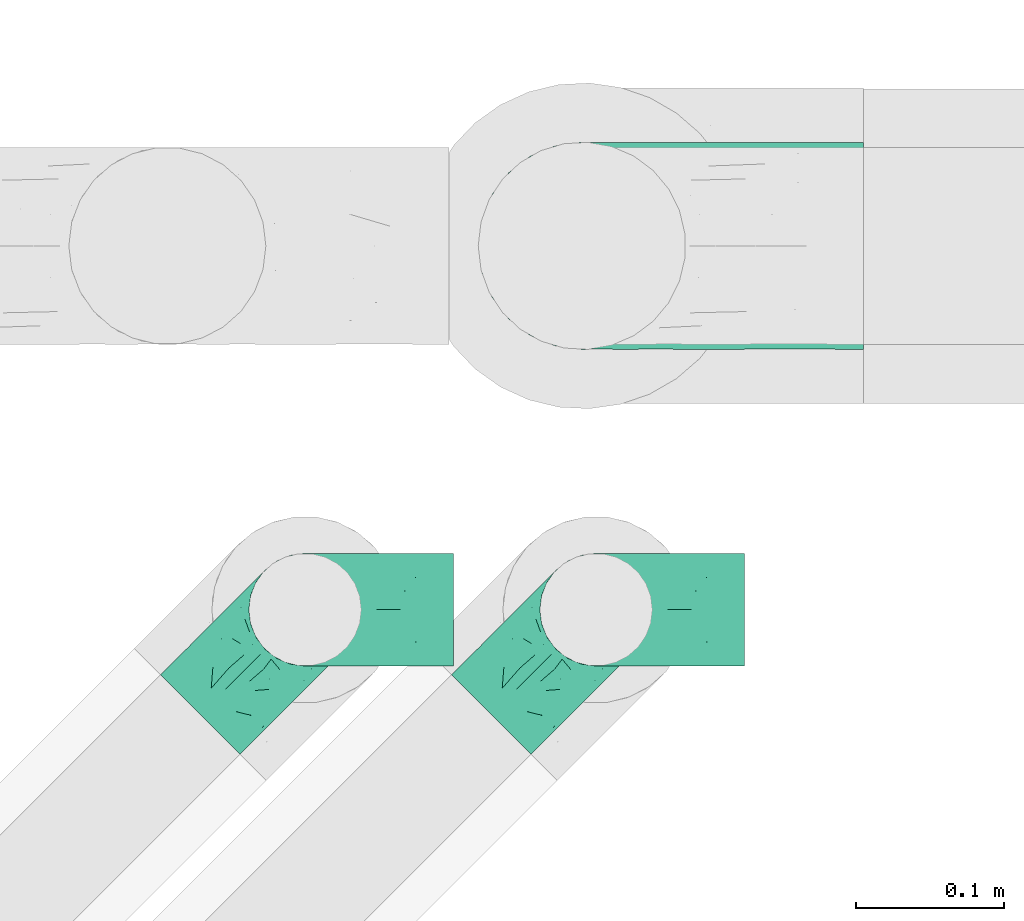
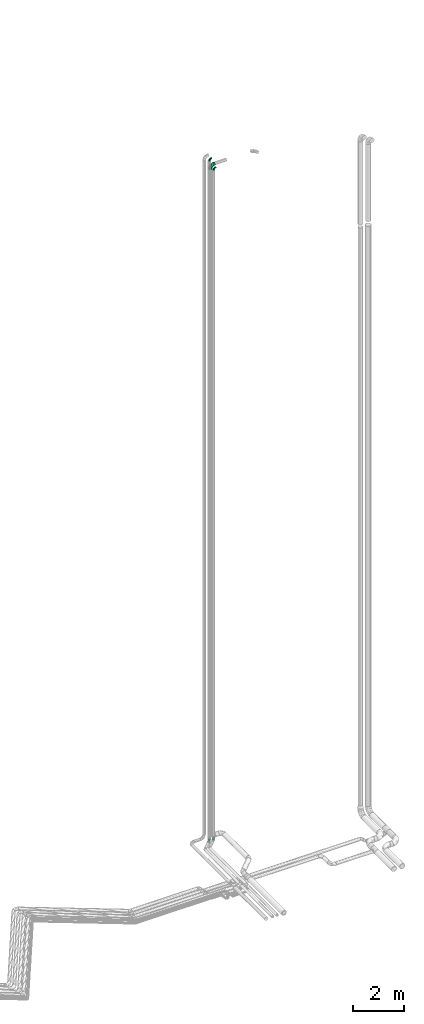
# One storey, part 71 of 93: 5 flow fittings.
"""IFC2X3 building model written with IfcOpenShell, lengths in millimetres."""

from ifc_helpers import new_model, entity, si_unit, converted_unit, derived_unit, direction, frame, origin, place, context, subcontext, project, spatial, faceted_brep, source, transform, mapped, material, type_object, type_shapes, element, save


model = new_model("IFC2X3")

# Units and contexts
model_context = context("Model", 3, precision=0.01, world=origin(), true_north=direction((6.12303176911189e-17, 1.0)))
body_context = subcontext(model_context, "Body", "Model", "MODEL_VIEW")
ifc_project = project(units=[si_unit("LENGTHUNIT", "METRE", prefix="MILLI"), si_unit("AREAUNIT", "SQUARE_METRE"), si_unit("VOLUMEUNIT", "CUBIC_METRE"), converted_unit("PLANEANGLEUNIT", "DEGREE", entity("IfcRatioMeasure", 0.0174532925199433), si_unit("PLANEANGLEUNIT", "RADIAN"), dimensions=[0, 0, 0, 0, 0, 0, 0]), si_unit("MASSUNIT", "GRAM", prefix="KILO"), derived_unit("MASSDENSITYUNIT", [(si_unit("MASSUNIT", "GRAM", prefix="KILO"), 1), (si_unit("LENGTHUNIT", "METRE"), -3)]), derived_unit("MOMENTOFINERTIAUNIT", [(si_unit("LENGTHUNIT", "METRE"), 4)]), si_unit("TIMEUNIT", "SECOND"), si_unit("FREQUENCYUNIT", "HERTZ"), si_unit("THERMODYNAMICTEMPERATUREUNIT", "DEGREE_CELSIUS"), derived_unit("THERMALTRANSMITTANCEUNIT", [(si_unit("MASSUNIT", "GRAM", prefix="KILO"), 1), (si_unit("THERMODYNAMICTEMPERATUREUNIT", "KELVIN"), -1), (si_unit("TIMEUNIT", "SECOND"), -3)]), derived_unit("VOLUMETRICFLOWRATEUNIT", [(si_unit("LENGTHUNIT", "METRE"), 3), (si_unit("TIMEUNIT", "SECOND"), -1)]), derived_unit("MASSFLOWRATEUNIT", [(si_unit("MASSUNIT", "GRAM", prefix="KILO"), 1), (si_unit("TIMEUNIT", "SECOND"), -1)]), derived_unit("ROTATIONALFREQUENCYUNIT", [(si_unit("TIMEUNIT", "SECOND"), -1)]), si_unit("ELECTRICCURRENTUNIT", "AMPERE"), si_unit("ELECTRICVOLTAGEUNIT", "VOLT"), si_unit("POWERUNIT", "WATT"), si_unit("FORCEUNIT", "NEWTON", prefix="KILO"), si_unit("ILLUMINANCEUNIT", "LUX"), si_unit("LUMINOUSFLUXUNIT", "LUMEN"), si_unit("LUMINOUSINTENSITYUNIT", "CANDELA"), derived_unit("USERDEFINED", [(si_unit("MASSUNIT", "GRAM", prefix="KILO"), -1), (si_unit("LENGTHUNIT", "METRE"), -2), (si_unit("TIMEUNIT", "SECOND"), 3), (si_unit("LUMINOUSFLUXUNIT", "LUMEN"), 1)]), derived_unit("LINEARVELOCITYUNIT", [(si_unit("LENGTHUNIT", "METRE"), 1), (si_unit("TIMEUNIT", "SECOND"), -1)]), si_unit("PRESSUREUNIT", "PASCAL"), derived_unit("USERDEFINED", [(si_unit("LENGTHUNIT", "METRE"), -2), (si_unit("MASSUNIT", "GRAM", prefix="KILO"), 1), (si_unit("TIMEUNIT", "SECOND"), -2)]), derived_unit("LINEARFORCEUNIT", [(si_unit("MASSUNIT", "GRAM", prefix="KILO"), 1), (si_unit("LENGTHUNIT", "METRE"), 1), (si_unit("TIMEUNIT", "SECOND"), -2), (si_unit("LENGTHUNIT", "METRE"), -1)]), derived_unit("PLANARFORCEUNIT", [(si_unit("MASSUNIT", "GRAM", prefix="KILO"), 1), (si_unit("LENGTHUNIT", "METRE"), 1), (si_unit("TIMEUNIT", "SECOND"), -2), (si_unit("LENGTHUNIT", "METRE"), -2)])], contexts=[model_context])

# Site, building, storey
site_placement = place(None, origin())
site = spatial("IfcSite", under=ifc_project, at=site_placement, CompositionType="ELEMENT")
building_placement = place(site_placement, origin())
building = spatial("IfcBuilding", under=site, at=building_placement, CompositionType="ELEMENT")
storey_placement = place(building_placement, frame((0.0, 0.0, -4200.0)))
storey = spatial("IfcBuildingStorey", under=building, at=storey_placement, CompositionType="ELEMENT", Elevation=-4200.0)

# Flow fittings
ifc_material = material()
pipe_fitting_type_1 = type_object("IfcPipeFittingType", Name="ADSK_2", PredefinedType="NOTDEFINED", material=ifc_material)
shared_shape_1 = source(origin(), body_context, "Body", "Brep", [
    faceted_brep([(-100.0, 19.0, -32.91), (-100.0, 9.84, -36.71), (-100.0, 0.0, -38.0), (-100.0, -9.84, -36.71), (-100.0, -19.0, -32.91), (-100.0, -26.87, -26.87), (-100.0, -32.91, -19.0), (-100.0, -36.71, -9.84), (-100.0, -38.0, 0.0), (-100.0, -36.71, 9.84), (-100.0, -32.91, 19.0), (-100.0, -26.87, 26.87), (-100.0, -19.0, 32.91), (-100.0, -9.84, 36.71), (-100.0, 0.0, 38.0), (-100.0, 9.84, 36.71), (-100.0, 19.0, 32.91), (-100.0, 26.87, 26.87), (-100.0, 32.91, 19.0), (-100.0, 36.71, 9.84), (-100.0, 38.0, 0.0), (-100.0, 36.71, -9.84), (-100.0, 32.91, -19.0), (-100.0, 26.87, -26.87), (0.0, 100.0, -38.0), (-9.84, 100.0, -36.71), (-19.0, 100.0, -32.91), (-26.87, 100.0, -26.87), (-32.91, 100.0, -19.0), (-36.71, 100.0, -9.84), (-38.0, 100.0, 0.0), (-36.71, 100.0, 9.84), (-32.91, 100.0, 19.0), (-26.87, 100.0, 26.87), (-19.0, 100.0, 32.91), (-9.84, 100.0, 36.71), (0.0, 100.0, 38.0), (9.84, 100.0, 36.71), (19.0, 100.0, 32.91), (26.87, 100.0, 26.87), (32.91, 100.0, 19.0), (36.71, 100.0, 9.84), (38.0, 100.0, 0.0), (36.71, 100.0, -9.84), (32.91, 100.0, -19.0), (26.87, 100.0, -26.87), (19.0, 100.0, -32.91), (9.84, 100.0, -36.71), (-40.69, 71.44, 16.62), (-81.22, -35.53, 0.0), (-67.52, -31.95, 12.5), (-8.97, -2.95, 6.59), (-11.71, -2.76, 13.62), (-24.68, -14.61, 8.04), (-64.28, -33.3, 0.0), (-83.72, 23.85, 30.89), (-76.19, 33.07, 24.6), (-74.13, -28.58, 21.76), (13.92, 43.47, 26.56), (5.03, 42.28, 32.41), (2.17, 22.78, 25.61), (20.11, 65.77, 28.71), (-65.77, -20.11, 28.71), (-74.23, -13.22, 34.41), (-44.44, -24.14, 12.16), (-47.64, -26.4, 0.0), (-31.0, -19.51, 0.0), (-54.86, 48.59, 21.12), (-81.56, 37.18, 15.86), (-42.28, -5.03, 32.41), (-52.67, 2.67, 37.1), (-14.76, 85.65, 35.5), (-6.46, 75.04, 37.87), (-58.38, 40.19, 26.6), (-15.88, 37.27, 37.68), (-29.21, 13.39, 36.1), (-10.53, 30.95, 35.7), (-77.78, -4.12, 37.45), (-2.67, 52.67, 37.1), (-76.41, 41.64, 8.45), (-71.15, 7.29, 37.89), (-32.26, 79.13, 24.41), (-44.28, 53.84, 26.08), (-25.18, 76.9, 31.2), (19.6, 43.38, 19.97), (6.25, 18.29, 16.9), (19.92, 34.73, 10.46), (-60.8, 50.97, 7.63), (-76.27, 42.72, 0.0), (-77.34, 15.98, 35.72), (-15.11, 15.11, 32.27), (-22.78, -2.17, 25.61), (28.58, 74.13, 21.76), (31.95, 67.52, 12.5), (-51.02, 30.39, 34.96), (-54.69, 20.06, 37.12), (26.4, 47.64, 0.0), (-51.15, 12.85, 38.0), (-32.84, 22.95, 37.94), (4.12, 77.78, 37.45), (-43.38, -19.6, 19.97), (35.53, 81.22, 0.0), (13.22, 74.23, 34.41), (-39.82, 82.33, 7.34), (-42.72, 76.27, 0.0), (-33.83, 52.47, 33.18), (-48.09, 40.81, 31.48), (-56.16, 56.16, 0.0), (-48.2, 64.18, 8.55), (-18.69, 66.93, 35.98), (-49.98, 57.58, 16.12), (-62.54, 46.99, 14.59), (-43.26, -12.84, 27.42), (-17.52, 48.72, 37.89), (-64.19, 29.4, 31.78), (-27.05, 50.9, 36.03), (-36.14, 36.14, 36.75), (-23.99, -8.71, 19.44), (6.3, 13.34, 7.98), (19.51, 31.0, 0.0), (-7.64, 6.3, 21.15), (-16.71, -8.55, 0.0), (33.3, 64.28, 0.0), (-2.42, 2.42, 0.0), (8.55, 16.71, 0.0), (-85.65, 14.76, -35.5), (-23.85, 83.72, -30.89), (-33.07, 76.19, -24.6), (-75.04, 6.46, -37.87), (-37.27, 15.88, -37.68), (-13.39, 29.21, -36.1), (-30.95, 10.53, -35.7), (-79.13, 32.26, -24.41), (-76.9, 25.18, -31.2), (6.3, 13.34, -7.98), (-11.71, -2.76, -13.62), (6.25, 18.29, -16.9), (-82.33, 39.82, -7.34), (-66.93, 18.69, -35.98), (-48.72, 17.52, -37.89), (-64.18, 48.2, -8.55), (31.95, 67.52, -12.5), (28.58, 74.13, -21.76), (-52.47, 33.83, -33.18), (4.12, 77.78, -37.45), (-7.29, 71.15, -37.89), (-15.98, 77.34, -35.72), (-67.52, -31.95, -12.5), (-30.39, 51.02, -34.96), (-20.06, 54.69, -37.12), (-48.59, 54.86, -21.12), (-37.18, 81.56, -15.86), (-74.13, -28.58, -21.76), (-29.4, 64.19, -31.78), (-40.81, 48.09, -31.48), (-40.19, 58.38, -26.6), (-65.77, -20.11, -28.71), (-74.23, -13.22, -34.41), (-39.81, -22.62, -10.22), (-77.78, -4.12, -37.45), (-43.38, -19.6, -19.97), (-12.85, 51.15, -38.0), (-22.95, 32.84, -37.94), (-71.44, 40.69, -16.62), (19.6, 43.38, -19.97), (20.11, 65.77, -28.71), (-52.67, 2.67, -37.1), (-53.84, 44.28, -26.08), (-41.64, 76.41, -8.45), (-23.99, -8.71, -19.44), (-43.47, -13.92, -26.56), (-22.78, -2.17, -25.61), (-20.59, -12.11, -6.83), (13.22, 74.23, -34.41), (5.03, 42.28, -32.41), (-2.67, 52.67, -37.1), (19.92, 34.73, -10.46), (-42.28, -5.03, -32.41), (12.84, 43.26, -27.42), (-50.97, 60.8, -7.63), (-57.58, 49.98, -16.12), (-46.99, 62.54, -14.59), (-50.9, 27.05, -36.03), (-36.14, 36.14, -36.75), (-15.11, 15.11, -32.27), (2.17, 22.78, -25.61), (-7.64, 6.3, -21.15), (-6.28, -0.33, -7.3)], [[[0, 1, 2, 3, 4, 5, 6, 7, 8, 9, 10, 11, 12, 13, 14, 15, 16, 17, 18, 19, 20, 21, 22, 23]], [[24, 25, 26, 27, 28, 29, 30, 31, 32, 33, 34, 35, 36, 37, 38, 39, 40, 41, 42, 43, 44, 45, 46, 47]], [[32, 31, 48]], [[49, 50, 9]], [[51, 52, 53]], [[9, 50, 10]], [[54, 50, 49]], [[17, 55, 56]], [[11, 10, 57]], [[58, 59, 60]], [[61, 39, 38]], [[62, 12, 11]], [[62, 63, 12]], [[64, 65, 66]], [[56, 67, 68]], [[63, 69, 70]], [[35, 71, 72]], [[67, 56, 73]], [[74, 75, 76]], [[16, 55, 17]], [[13, 77, 14]], [[76, 78, 74]], [[68, 79, 19]], [[18, 17, 56]], [[14, 77, 80]], [[20, 19, 79]], [[81, 82, 83]], [[84, 85, 86]], [[87, 88, 79]], [[18, 68, 19]], [[15, 89, 16]], [[14, 80, 15]], [[85, 84, 60]], [[90, 69, 91]], [[92, 84, 93]], [[94, 89, 95]], [[86, 96, 93]], [[83, 71, 34]], [[95, 97, 98]], [[37, 36, 99]], [[40, 39, 92]], [[40, 93, 41]], [[66, 53, 64]], [[92, 93, 40]], [[57, 100, 62]], [[93, 101, 41]], [[93, 84, 86]], [[61, 102, 59]], [[34, 33, 83]], [[103, 48, 31]], [[50, 57, 10]], [[104, 103, 30]], [[94, 105, 106]], [[104, 107, 108]], [[12, 63, 13]], [[83, 109, 71]], [[83, 105, 109]], [[33, 81, 83]], [[67, 110, 111]], [[108, 103, 104]], [[112, 69, 62]], [[34, 71, 35]], [[36, 35, 72]], [[109, 113, 72]], [[102, 38, 37]], [[102, 61, 38]], [[114, 106, 73]], [[89, 15, 80]], [[33, 32, 81]], [[115, 105, 116]], [[109, 115, 113]], [[99, 72, 78]], [[111, 87, 79]], [[108, 87, 110]], [[69, 63, 62]], [[77, 63, 70]], [[100, 117, 112]], [[69, 90, 75]], [[99, 102, 37]], [[78, 76, 59]], [[78, 59, 102]], [[59, 90, 60]], [[100, 57, 50]], [[62, 11, 57]], [[39, 61, 92]], [[84, 92, 61]], [[95, 89, 80]], [[55, 89, 114]], [[83, 82, 105]], [[94, 106, 114]], [[98, 113, 116]], [[78, 72, 113]], [[98, 116, 95]], [[98, 70, 75]], [[32, 48, 81]], [[82, 81, 48]], [[91, 112, 117]], [[60, 84, 58]], [[113, 115, 116]], [[118, 119, 86]], [[90, 91, 60]], [[91, 117, 120]], [[72, 99, 36]], [[102, 99, 78]], [[63, 77, 13]], [[80, 77, 70]], [[95, 80, 97]], [[94, 95, 116]], [[56, 68, 18]], [[79, 68, 111]], [[110, 87, 111]], [[79, 88, 20]], [[108, 107, 87]], [[88, 87, 107]], [[120, 60, 91]], [[66, 121, 53]], [[118, 86, 85]], [[122, 93, 96]], [[52, 118, 85]], [[118, 123, 124, 119]], [[48, 103, 108]], [[30, 103, 31]], [[89, 55, 16]], [[56, 55, 114]], [[80, 70, 97]], [[70, 98, 97]], [[105, 94, 116]], [[89, 94, 114]], [[105, 82, 106]], [[73, 106, 82]], [[67, 73, 82]], [[114, 73, 56]], [[110, 82, 48]], [[67, 111, 68]], [[82, 110, 67]], [[108, 110, 48]], [[69, 75, 70]], [[76, 75, 90]], [[59, 76, 90]], [[78, 113, 74]], [[113, 98, 74]], [[75, 74, 98]], [[9, 8, 49]], [[101, 93, 122]], [[101, 42, 41]], [[72, 71, 109]], [[50, 54, 65]], [[117, 53, 52]], [[109, 105, 115]], [[100, 112, 62]], [[91, 69, 112]], [[123, 51, 121]], [[120, 52, 85]], [[52, 120, 117]], [[60, 120, 85]], [[51, 118, 52]], [[100, 64, 117]], [[50, 64, 100]], [[121, 51, 53]], [[118, 51, 123]], [[84, 61, 58]], [[59, 58, 61]], [[86, 119, 96]], [[65, 64, 50]], [[117, 64, 53]], [[125, 1, 0]], [[27, 126, 127]], [[2, 1, 128]], [[129, 130, 131]], [[132, 133, 23]], [[134, 135, 136]], [[88, 137, 20]], [[138, 139, 128]], [[88, 107, 140]], [[141, 142, 44]], [[138, 133, 143]], [[24, 144, 145]], [[146, 25, 145]], [[125, 133, 138]], [[6, 147, 7]], [[148, 146, 149]], [[147, 49, 7]], [[127, 150, 151]], [[147, 6, 152]], [[153, 154, 155]], [[156, 4, 157]], [[140, 137, 88]], [[24, 145, 25]], [[43, 42, 101]], [[65, 147, 158]], [[148, 143, 154]], [[159, 3, 2]], [[147, 152, 160]], [[149, 161, 162]], [[156, 5, 4]], [[137, 163, 21]], [[142, 164, 165]], [[131, 166, 129]], [[28, 151, 29]], [[167, 133, 132]], [[168, 30, 29]], [[169, 170, 171]], [[127, 28, 27]], [[150, 127, 155]], [[135, 172, 158]], [[26, 25, 146]], [[1, 125, 128]], [[22, 21, 163]], [[126, 27, 26]], [[151, 168, 29]], [[24, 47, 144]], [[45, 165, 46]], [[0, 23, 133]], [[173, 174, 175]], [[119, 134, 176]], [[142, 45, 44]], [[173, 46, 165]], [[141, 44, 43]], [[46, 173, 47]], [[141, 101, 122]], [[156, 157, 177]], [[157, 4, 3]], [[101, 141, 43]], [[178, 174, 165]], [[169, 160, 170]], [[6, 5, 152]], [[170, 177, 171]], [[158, 147, 160]], [[104, 168, 179]], [[141, 96, 176]], [[150, 180, 181]], [[23, 22, 132]], [[182, 143, 183]], [[138, 182, 139]], [[159, 128, 166]], [[181, 179, 168]], [[140, 179, 180]], [[159, 157, 3]], [[166, 131, 177]], [[166, 177, 157]], [[177, 184, 171]], [[174, 173, 165]], [[144, 173, 175]], [[178, 164, 185]], [[174, 184, 130]], [[5, 156, 152]], [[160, 152, 156]], [[164, 142, 141]], [[165, 45, 142]], [[149, 146, 145]], [[126, 146, 153]], [[133, 167, 143]], [[148, 154, 153]], [[162, 139, 183]], [[166, 128, 139]], [[162, 183, 149]], [[162, 175, 130]], [[22, 163, 132]], [[167, 132, 163]], [[174, 185, 184]], [[136, 176, 134]], [[185, 136, 186]], [[158, 172, 66]], [[136, 185, 164]], [[171, 184, 185]], [[128, 159, 2]], [[157, 159, 166]], [[173, 144, 47]], [[145, 144, 175]], [[149, 145, 161]], [[148, 149, 183]], [[127, 151, 28]], [[168, 151, 181]], [[180, 179, 181]], [[168, 104, 30]], [[140, 107, 179]], [[104, 179, 107]], [[176, 136, 164]], [[135, 169, 186]], [[141, 176, 164]], [[134, 119, 124, 123]], [[158, 66, 65]], [[187, 172, 135]], [[163, 137, 140]], [[20, 137, 21]], [[146, 126, 26]], [[127, 126, 153]], [[145, 175, 161]], [[175, 162, 161]], [[143, 148, 183]], [[146, 148, 153]], [[143, 167, 154]], [[155, 154, 167]], [[150, 155, 167]], [[153, 155, 127]], [[180, 167, 163]], [[150, 181, 151]], [[167, 180, 150]], [[140, 180, 163]], [[174, 130, 175]], [[131, 130, 184]], [[177, 131, 184]], [[166, 139, 129]], [[139, 162, 129]], [[130, 129, 162]], [[49, 147, 54]], [[49, 8, 7]], [[133, 125, 0]], [[128, 125, 138]], [[158, 160, 169]], [[65, 54, 147]], [[187, 135, 134]], [[187, 121, 172]], [[134, 123, 187]], [[139, 182, 183]], [[121, 187, 123]], [[121, 66, 172]], [[138, 143, 182]], [[160, 156, 170]], [[177, 170, 156]], [[186, 169, 171]], [[158, 169, 135]], [[185, 186, 171]], [[135, 186, 136]], [[164, 178, 165]], [[185, 174, 178]], [[96, 141, 122]], [[96, 119, 176]]]),
])
type_shapes(pipe_fitting_type_1, [shared_shape_1])
for number, where, z_axis, x_axis, name in (
    (1, (25108.72, 12070.0, 3000.0), (0.707106781186543, -0.707106781186552, 0.0), (0.707106781186552, 0.707106781186543, 0.0), "ADSK_2"),
    (2, (24912.31, 12070.0, 3000.0), (0.707106781186536, -0.707106781186559, 0.0), (0.707106781186559, 0.707106781186536, 0.0), "ADSK_2"),
    (3, (25108.72, 12070.0, 35000.0), (0.0, 1.0, 0.0), (0.0, 0.0, 1.0), "ADSK_2"),
    (4, (24912.31, 12070.0, 35500.0), (0.0, 1.0, 0.0), (0.0, 0.0, 1.0), "ADSK_2"),
):
    element("IfcFlowFitting", number, at=place(storey_placement, frame(where, z_axis=z_axis, x_axis=x_axis)), inside=storey, type_object=pipe_fitting_type_1, material=ifc_material, Name=name, ObjectType="ADSK_2", context=body_context, shape_type="MappedRepresentation", body=[
        mapped(shared_shape_1, transform((0.0, 0.0, 0.0), scale=1.0)),
    ])
pipe_fitting_type_2 = type_object("IfcPipeFittingType", Name="ADSK_1", PredefinedType="NOTDEFINED", material=ifc_material)
shared_shape_2 = source(origin(), body_context, "Body", "Brep", [
    faceted_brep([(-190.0, 18.08, -67.47), (-190.0, 0.0, -69.85), (-190.0, -18.08, -67.47), (-190.0, -34.93, -60.49), (-190.0, -49.39, -49.39), (-190.0, -60.49, -34.93), (-190.0, -67.47, -18.08), (-190.0, -69.85, 0.0), (-190.0, -67.47, 18.08), (-190.0, -60.49, 34.92), (-190.0, -49.39, 49.39), (-190.0, -34.93, 60.49), (-190.0, -18.08, 67.47), (-190.0, 0.0, 69.85), (-190.0, 18.08, 67.47), (-190.0, 34.92, 60.49), (-190.0, 49.39, 49.39), (-190.0, 60.49, 34.92), (-190.0, 67.47, 18.08), (-190.0, 69.85, 0.0), (-190.0, 67.47, -18.08), (-190.0, 60.49, -34.93), (-190.0, 49.39, -49.39), (-190.0, 34.92, -60.49), (18.08, 190.0, -67.47), (0.0, 190.0, -69.85), (-18.08, 190.0, -67.47), (-34.92, 190.0, -60.49), (-49.39, 190.0, -49.39), (-60.49, 190.0, -34.93), (-67.47, 190.0, -18.08), (-69.85, 190.0, 0.0), (-67.47, 190.0, 18.08), (-60.49, 190.0, 34.92), (-49.39, 190.0, 49.39), (-34.92, 190.0, 60.49), (-18.08, 190.0, 67.47), (0.0, 190.0, 69.85), (18.08, 190.0, 67.47), (34.93, 190.0, 60.49), (49.39, 190.0, 49.39), (60.49, 190.0, 34.92), (67.47, 190.0, 18.08), (69.85, 190.0, 0.0), (67.47, 190.0, -18.08), (60.49, 190.0, -34.93), (49.39, 190.0, -49.39), (34.93, 190.0, -60.49), (-29.62, 146.98, 65.62), (-13.75, 135.37, 69.64), (-124.22, -36.33, 52.83), (-140.23, -52.18, 40.04), (-80.56, -34.09, 36.78), (-140.97, -24.01, 63.29), (-80.93, -8.05, 59.8), (-100.59, 5.62, 68.24), (-125.19, -57.65, 22.9), (-139.31, -64.86, 0.0), (-28.7, -8.91, 22.6), (-45.64, -26.06, 0.0), (-6.26, 6.26, 0.0), (-105.44, 36.89, 68.2), (-118.83, 43.56, 64.34), (-146.98, 29.62, 65.62), (-71.47, -38.86, 17.07), (-90.56, -50.07, 0.0), (-0.6, 27.02, 35.97), (-44.76, -2.31, 47.74), (-42.86, -12.1, 35.78), (-148.03, -7.38, 68.85), (-135.37, 13.75, 69.64), (-67.48, 159.11, 28.79), (36.32, 124.15, 52.82), (-38.8, 102.11, 68.2), (-24.59, 96.61, 69.85), (-81.73, 130.22, 21.92), (-65.15, 30.31, 68.68), (-27.72, 54.52, 66.49), (-44.98, 61.25, 69.74), (-75.73, 152.87, 0.0), (-159.11, 67.48, 28.79), (-130.22, 81.73, 21.92), (-152.87, 75.73, 0.0), (-76.65, 126.59, 35.57), (-101.51, 101.51, 25.92), (-96.74, 96.74, 38.75), (-144.94, 60.97, 45.11), (-159.57, 43.91, 56.71), (-119.38, 92.8, 0.0), (50.07, 90.56, 0.0), (57.42, 124.25, 22.84), (38.8, 71.6, 17.49), (64.86, 139.31, 0.0), (52.17, 140.21, 40.03), (33.37, 79.39, 36.99), (24.0, 140.95, 63.29), (8.03, 80.92, 59.81), (-82.61, -22.17, 50.94), (7.38, 148.03, 68.85), (-100.26, 79.14, 51.33), (-75.76, 96.1, 55.72), (-76.12, 111.95, 46.7), (-92.8, 119.38, 0.0), (-104.27, 104.27, 12.31), (10.07, 27.17, 16.15), (26.06, 45.64, 0.0), (-61.21, 144.14, 45.16), (-44.13, 158.15, 56.77), (-55.26, 120.41, 58.38), (9.95, 57.03, 48.64), (29.48, 90.08, 47.56), (-5.62, 100.59, 68.24), (-122.78, 54.24, 58.28), (-86.25, 73.26, 61.12), (-95.79, 24.47, 69.85), (-126.59, 76.65, 35.57), (-17.15, 26.56, 50.85), (-29.82, 29.82, 59.54), (-70.73, 11.02, 65.19), (-58.6, 94.58, 64.16), (-71.14, 66.1, 67.41), (-158.15, 44.13, -56.77), (33.37, 79.39, -36.99), (10.07, 27.17, -16.15), (-0.6, 27.02, -35.97), (-100.59, 5.62, -68.24), (-148.03, -7.38, -68.85), (-135.37, 13.75, -69.64), (-130.22, 81.73, -21.92), (-146.98, 29.62, -65.62), (-102.11, 38.8, -68.2), (-96.61, 24.59, -69.85), (-83.02, -24.86, -48.76), (-44.76, -2.31, -47.74), (-80.56, -34.09, -36.78), (-122.68, -57.24, -22.15), (-71.43, -38.87, -16.95), (-104.27, 104.27, -12.31), (-159.11, 67.48, -28.79), (-144.14, 61.21, -45.16), (7.38, 148.03, -68.85), (-13.75, 135.37, -69.64), (-79.14, 100.26, -51.33), (-96.1, 75.76, -55.72), (-111.95, 76.12, -46.7), (-80.93, -8.05, -59.8), (-124.22, -36.33, -52.83), (-140.23, -52.18, -40.04), (-24.47, 95.79, -69.85), (-36.89, 105.44, -68.2), (-150.18, -65.36, -13.92), (-43.56, 118.83, -64.34), (-29.62, 146.98, -65.62), (38.8, 71.6, -17.49), (-81.73, 130.22, -21.92), (-28.7, -8.91, -22.6), (-54.24, 122.78, -58.28), (-73.26, 86.25, -61.12), (-61.25, 44.98, -69.74), (-30.31, 65.15, -68.68), (-54.52, 27.72, -66.49), (-101.51, 101.51, -25.92), (-126.59, 76.65, -35.57), (-96.74, 96.74, -38.75), (-67.48, 159.11, -28.79), (-120.41, 55.26, -58.38), (-43.91, 159.57, -56.71), (24.0, 140.95, -63.29), (8.03, 80.92, -59.81), (-5.62, 100.59, -68.24), (-60.97, 144.94, -45.11), (36.32, 124.15, -52.82), (57.42, 124.25, -22.84), (52.17, 140.21, -40.03), (-140.97, -24.01, -63.29), (9.95, 57.03, -48.64), (-76.65, 126.59, -35.57), (22.84, 89.04, -52.94), (-11.03, 70.74, -65.2), (-29.82, 29.82, -59.54), (-94.58, 58.6, -64.16), (-66.1, 71.14, -67.41), (-31.42, -3.01, -36.09), (-13.88, 24.32, -46.86)], [[[0, 1, 2, 3, 4, 5, 6, 7, 8, 9, 10, 11, 12, 13, 14, 15, 16, 17, 18, 19, 20, 21, 22, 23]], [[24, 25, 26, 27, 28, 29, 30, 31, 32, 33, 34, 35, 36, 37, 38, 39, 40, 41, 42, 43, 44, 45, 46, 47]], [[36, 48, 49]], [[50, 51, 52]], [[53, 54, 55]], [[56, 9, 8]], [[8, 7, 57]], [[58, 59, 60]], [[51, 9, 56]], [[61, 62, 63]], [[59, 58, 64]], [[59, 64, 65]], [[11, 10, 50]], [[66, 67, 68]], [[50, 53, 11]], [[69, 70, 13]], [[71, 33, 32]], [[72, 40, 39]], [[73, 74, 49]], [[63, 15, 14]], [[13, 70, 14]], [[71, 32, 75]], [[12, 69, 13]], [[76, 77, 78]], [[32, 79, 75]], [[18, 80, 81]], [[63, 14, 70]], [[82, 19, 18]], [[83, 84, 85]], [[86, 16, 87]], [[82, 81, 88]], [[82, 18, 81]], [[15, 87, 16]], [[83, 71, 75]], [[52, 56, 64]], [[49, 37, 36]], [[89, 90, 91]], [[36, 35, 48]], [[42, 41, 90]], [[89, 92, 90]], [[11, 53, 12]], [[73, 78, 74]], [[65, 56, 57]], [[40, 72, 93]], [[94, 90, 93]], [[41, 40, 93]], [[72, 95, 96]], [[95, 39, 38]], [[8, 57, 56]], [[43, 42, 92]], [[67, 54, 97]], [[38, 37, 98]], [[99, 100, 101]], [[102, 75, 79]], [[51, 10, 9]], [[102, 88, 103]], [[31, 79, 32]], [[104, 60, 105]], [[106, 34, 33]], [[84, 103, 81]], [[91, 105, 89]], [[107, 35, 34]], [[106, 108, 107]], [[49, 48, 73]], [[104, 105, 91]], [[16, 86, 17]], [[58, 104, 66]], [[109, 110, 96]], [[111, 98, 49]], [[112, 113, 99]], [[92, 42, 90]], [[95, 72, 39]], [[70, 114, 61]], [[80, 18, 17]], [[101, 106, 83]], [[99, 86, 112]], [[115, 81, 80]], [[90, 94, 91]], [[94, 66, 104]], [[64, 58, 68]], [[56, 65, 64]], [[93, 72, 110]], [[90, 41, 93]], [[98, 95, 38]], [[111, 77, 96]], [[111, 96, 95]], [[67, 116, 117]], [[52, 51, 56]], [[50, 10, 51]], [[54, 53, 50]], [[69, 53, 55]], [[97, 52, 67]], [[118, 76, 55]], [[107, 48, 35]], [[73, 119, 120]], [[61, 63, 70]], [[63, 62, 87]], [[94, 104, 91]], [[58, 60, 104]], [[109, 66, 94]], [[67, 117, 54]], [[68, 67, 52]], [[116, 66, 109]], [[119, 48, 108]], [[73, 120, 78]], [[120, 61, 114]], [[78, 114, 76]], [[49, 98, 37]], [[95, 98, 111]], [[53, 69, 12]], [[70, 69, 55]], [[70, 55, 114]], [[120, 113, 62]], [[76, 114, 55]], [[120, 114, 78]], [[118, 55, 54]], [[76, 118, 77]], [[96, 77, 117]], [[111, 78, 77]], [[54, 117, 118]], [[77, 118, 117]], [[110, 109, 94]], [[116, 96, 117]], [[106, 107, 34]], [[48, 107, 108]], [[75, 84, 83]], [[106, 33, 71]], [[101, 83, 85]], [[106, 71, 83]], [[99, 101, 85]], [[108, 106, 101]], [[99, 85, 115]], [[113, 112, 62]], [[119, 113, 120]], [[100, 99, 113]], [[17, 86, 80]], [[115, 85, 84]], [[80, 86, 115]], [[99, 115, 86]], [[63, 87, 15]], [[86, 87, 112]], [[78, 111, 74]], [[111, 49, 74]], [[119, 100, 113]], [[101, 100, 108]], [[48, 119, 73]], [[119, 108, 100]], [[75, 102, 103]], [[115, 84, 81]], [[81, 103, 88]], [[75, 103, 84]], [[54, 50, 97]], [[52, 97, 50]], [[64, 68, 52]], [[66, 68, 58]], [[62, 61, 120]], [[87, 62, 112]], [[93, 110, 94]], [[96, 110, 72]], [[66, 116, 67]], [[96, 116, 109]], [[22, 121, 23]], [[122, 123, 124]], [[125, 126, 127]], [[20, 82, 128]], [[129, 130, 127]], [[130, 131, 127]], [[19, 82, 20]], [[132, 133, 134]], [[88, 128, 82]], [[135, 136, 65]], [[102, 137, 88]], [[138, 20, 128]], [[139, 22, 21]], [[140, 141, 25]], [[142, 143, 144]], [[145, 133, 132]], [[4, 146, 147]], [[141, 148, 149]], [[7, 6, 150]], [[138, 21, 20]], [[5, 4, 147]], [[149, 151, 152]], [[59, 65, 136]], [[122, 153, 123]], [[79, 30, 154]], [[134, 155, 136]], [[150, 65, 57]], [[156, 157, 142]], [[126, 2, 1]], [[134, 135, 147]], [[130, 158, 131]], [[159, 160, 158]], [[154, 161, 137]], [[0, 23, 129]], [[127, 1, 0]], [[162, 138, 128]], [[161, 163, 162]], [[30, 79, 31]], [[146, 4, 3]], [[154, 30, 164]], [[152, 27, 26]], [[165, 121, 139]], [[25, 24, 140]], [[25, 141, 26]], [[164, 30, 29]], [[27, 166, 28]], [[167, 168, 169]], [[141, 152, 26]], [[28, 170, 29]], [[47, 171, 167]], [[172, 89, 153]], [[59, 155, 60]], [[28, 166, 170]], [[46, 45, 173]], [[153, 89, 105]], [[105, 123, 153]], [[174, 146, 3]], [[171, 47, 46]], [[45, 44, 172]], [[7, 150, 57]], [[43, 92, 44]], [[122, 124, 175]], [[89, 172, 92]], [[171, 173, 122]], [[47, 167, 24]], [[173, 171, 46]], [[135, 150, 5]], [[0, 129, 127]], [[174, 3, 2]], [[79, 154, 102]], [[146, 174, 145]], [[44, 92, 172]], [[144, 139, 162]], [[142, 170, 156]], [[176, 154, 164]], [[105, 60, 123]], [[122, 172, 153]], [[45, 172, 173]], [[122, 173, 172]], [[167, 171, 177]], [[140, 167, 169]], [[177, 122, 175]], [[178, 159, 169]], [[134, 136, 135]], [[155, 59, 136]], [[134, 147, 146]], [[135, 5, 147]], [[126, 174, 2]], [[125, 160, 145]], [[125, 145, 174]], [[145, 179, 133]], [[121, 129, 23]], [[130, 180, 181]], [[149, 152, 141]], [[152, 151, 166]], [[60, 155, 123]], [[123, 155, 124]], [[182, 134, 133]], [[175, 179, 168]], [[183, 179, 175]], [[155, 182, 124]], [[180, 129, 165]], [[130, 181, 158]], [[181, 149, 148]], [[158, 148, 159]], [[127, 126, 1]], [[174, 126, 125]], [[167, 140, 24]], [[141, 140, 169]], [[141, 169, 148]], [[181, 157, 151]], [[159, 148, 169]], [[181, 148, 158]], [[178, 169, 168]], [[159, 178, 160]], [[145, 160, 179]], [[125, 158, 160]], [[168, 179, 178]], [[160, 178, 179]], [[175, 124, 183]], [[177, 175, 168]], [[139, 121, 22]], [[129, 121, 165]], [[128, 161, 162]], [[139, 21, 138]], [[144, 162, 163]], [[139, 138, 162]], [[142, 144, 163]], [[165, 139, 144]], [[142, 163, 176]], [[157, 156, 151]], [[180, 157, 181]], [[143, 142, 157]], [[29, 170, 164]], [[176, 163, 161]], [[164, 170, 176]], [[142, 176, 170]], [[152, 166, 27]], [[170, 166, 156]], [[158, 125, 131]], [[125, 127, 131]], [[180, 143, 157]], [[144, 143, 165]], [[129, 180, 130]], [[180, 165, 143]], [[128, 88, 137]], [[176, 161, 154]], [[154, 137, 102]], [[128, 137, 161]], [[5, 150, 6]], [[65, 150, 135]], [[134, 146, 132]], [[145, 132, 146]], [[134, 182, 155]], [[183, 182, 133]], [[151, 149, 181]], [[166, 151, 156]], [[182, 183, 124]], [[179, 183, 133]], [[167, 177, 168]], [[122, 177, 171]]]),
])
type_shapes(pipe_fitting_type_2, [shared_shape_2])
flow_fitting_placement = place(storey_placement, frame((25099.12, 12315.57, 35000.0), z_axis=(0.0, 1.0, 0.0), x_axis=(0.0, 0.0, 1.0)))
element("IfcFlowFitting", 5, at=flow_fitting_placement, inside=storey, type_object=pipe_fitting_type_2, material=ifc_material, Name="ADSK_1", ObjectType="ADSK_1", context=body_context, shape_type="MappedRepresentation", body=[
    mapped(shared_shape_2, transform((0.0, 0.0, 0.0), scale=1.0)),
])

save(model, "model.ifc")
